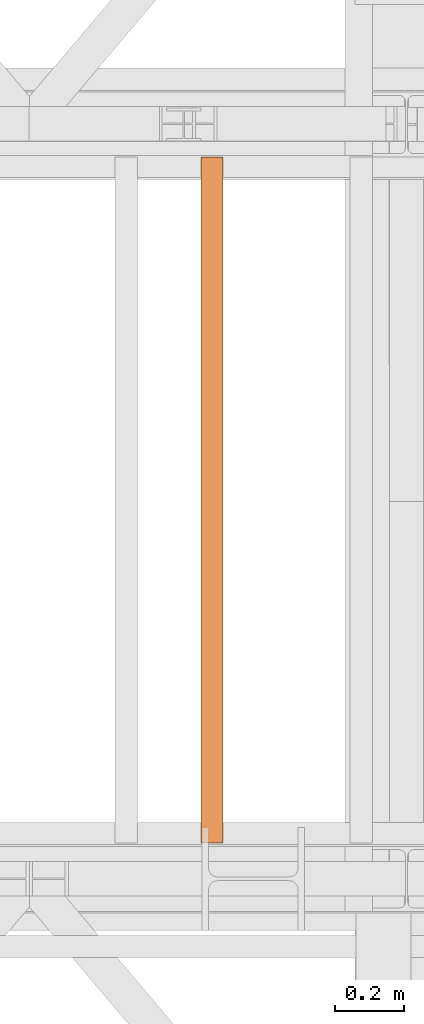
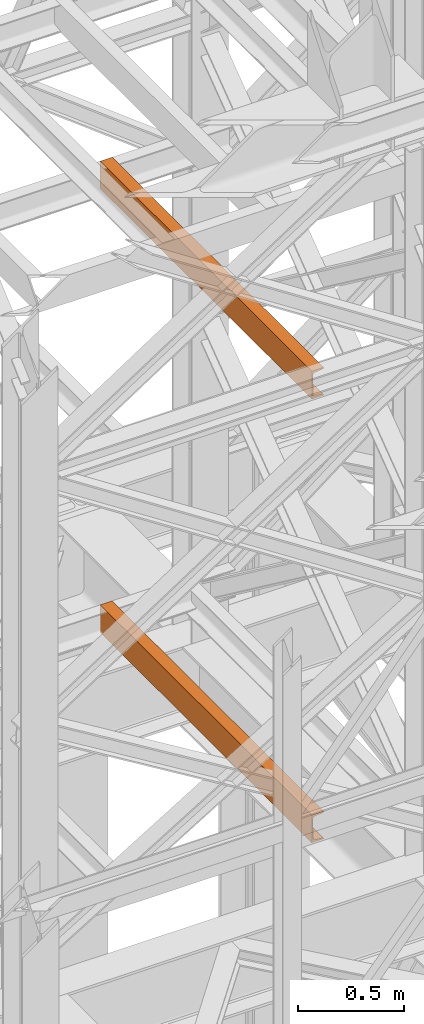
# One storey, part 161 of 208: 2 proxies.
"""IFC2X3 building model written with IfcOpenShell, lengths in millimetres."""

from ifc_helpers import new_model, entity, si_unit, converted_unit, frame, origin, origin_with_axes, place, context, subcontext, project, spatial, faceted_brep, element, save


model = new_model("IFC2X3")

# Units and contexts
model_context = context("Model", 3, precision=1e-05, world=origin())
plan_context = context("Plan", 3, precision=1e-05, world=origin())
body_context = subcontext(model_context, "Body", "Model", "MODEL_VIEW")
ifc_project = project(units=[si_unit("LENGTHUNIT", "METRE", prefix="MILLI"), converted_unit("PLANEANGLEUNIT", "DEGREE", entity("IfcPlaneAngleMeasure", 0.0174532925199433), si_unit("PLANEANGLEUNIT", "RADIAN"), dimensions=[0, 0, 0, 0, 0, 0, 0]), si_unit("AREAUNIT", "SQUARE_METRE"), si_unit("VOLUMEUNIT", "CUBIC_METRE")], contexts=[model_context, plan_context])

# Building, storey
building_placement = place(None, origin())
building = spatial("IfcBuilding", under=ifc_project, at=building_placement, CompositionType="COMPLEX")
storey_placement = place(building_placement, origin_with_axes())
storey = spatial("IfcBuildingStorey", under=building, at=storey_placement, Name="Geschoss", CompositionType="ELEMENT")

# Proxies
proxy_1_placement = place(storey_placement, frame((4893.254968528666, -15857.57439359615, 5524.960005364416), z_axis=(0.0, 0.0, 1.0), x_axis=(1.0, 0.0, 0.0)))
element("IfcBuildingElementProxy", 1, at=proxy_1_placement, inside=storey, context=body_context, shape_type="Brep", body=[
    faceted_brep([(0.01000000000203727, 2000.009997019768, 160.0100000000002), (65.01000000000204, 2000.009997019768, 160.0100000000002), (65.00999999999931, 0.01000000000021828, 160.0100000000002), (0.009999999999308784, 0.01000000000021828, 160.0100000000002), (65.01000000000204, 2000.009997019768, 160.0100000000002), (65.01000000000204, 2000.009997019768, 156.8875719297539), (65.00999999999931, 0.01000000000021828, 156.8875719297539), (65.00999999999931, 0.01000000000021828, 160.0100000000002), (65.01000000000204, 2000.009997019768, 156.8875719297539), (64.76726342282927, 2000.009997019768, 155.2717110918293), (64.76726342282655, 0.01000000000021828, 155.2717110918293), (65.00999999999931, 0.01000000000021828, 156.8875719297539), (64.76726342282927, 2000.009997019768, 155.2717110918293), (64.06053228585733, 2000.009997019768, 153.7984655565542), (64.06053228585824, 0.01000000000021828, 153.7984655565542), (64.76726342282655, 0.01000000000021828, 155.2717110918293), (64.06053228585733, 2000.009997019768, 153.7984655565542), (62.95215163847024, 2000.009997019768, 152.5978732961266), (62.95215163846751, 0.01000000000021828, 152.5978732961266), (64.06053228585824, 0.01000000000021828, 153.7984655565542), (62.95215163847024, 2000.009997019768, 152.5978732961266), (61.53995641148504, 2000.009997019768, 151.7759086082897), (61.53995641148231, 0.01000000000021828, 151.7759086082897), (62.95215163846751, 0.01000000000021828, 152.5978732961266), (61.53995641148504, 2000.009997019768, 151.7759086082897), (59.9485987225562, 2000.009997019768, 151.4050878978051), (59.94859872255347, 0.01000000000021828, 151.4050878978051), (61.53995641148231, 0.01000000000021828, 151.7759086082897), (59.9485987225562, 2000.009997019768, 151.4050878978051), (17.1726751660317, 2000.009997019768, 147.9830140132835), (17.17267516602897, 0.01000000000021828, 147.9830140132835), (59.94859872255347, 0.01000000000021828, 151.4050878978051), (17.1726751660317, 2000.009997019768, 147.9830140132835), (14.20840820801095, 2000.009997019768, 147.318026761528), (14.20840820800822, 0.01000000000021828, 147.318026761528), (17.17267516602897, 0.01000000000021828, 147.9830140132835), (14.20840820801095, 2000.009997019768, 147.318026761528), (11.43861959928836, 2000.009997019768, 145.7058782528511), (11.43861959928927, 0.01000000000021828, 145.7058782528511), (14.20840820800822, 0.01000000000021828, 147.318026761528), (11.43861959928836, 2000.009997019768, 145.7058782528511), (9.3226201815487, 2000.009997019768, 143.4138384829421), (9.322620181545972, 0.01000000000021828, 143.4138384829421), (11.43861959928927, 0.01000000000021828, 145.7058782528511), (9.3226201815487, 2000.009997019768, 143.4138384829421), (7.973406192788389, 2000.009997019768, 140.6012788246917), (7.97340619278566, 0.01000000000021828, 140.6012788246917), (9.322620181545972, 0.01000000000021828, 143.4138384829421), (7.973406192788389, 2000.009997019768, 140.6012788246917), (7.510000000002037, 2000.009997019768, 137.5164535886543), (7.509999999999309, 0.01000000000021828, 137.5164535886543), (7.97340619278566, 0.01000000000021828, 140.6012788246917), (7.510000000002037, 2000.009997019768, 137.5164535886543), (7.510000000002037, 2000.009997019768, 22.503546411348), (7.509999999999309, 0.01000000000021828, 22.503546411348), (7.509999999999309, 0.01000000000021828, 137.5164535886543), (7.510000000002037, 2000.009997019768, 22.503546411348), (7.973406192788389, 2000.009997019768, 19.41872117530875), (7.97340619278566, 0.01000000000021828, 19.41872117530875), (7.509999999999309, 0.01000000000021828, 22.503546411348), (7.973406192788389, 2000.009997019768, 19.41872117530875), (9.3226201815487, 2000.009997019768, 16.60616151705835), (9.322620181545972, 0.01000000000021828, 16.60616151705835), (7.97340619278566, 0.01000000000021828, 19.41872117530875), (9.3226201815487, 2000.009997019768, 16.60616151705835), (11.43861959928836, 2000.009997019768, 14.31412174714933), (11.43861959928927, 0.01000000000021828, 14.31412174714933), (9.322620181545972, 0.01000000000021828, 16.60616151705835), (11.43861959928836, 2000.009997019768, 14.31412174714933), (14.13462866898408, 2000.009997019768, 12.74491643400688), (14.13462866898499, 0.01000000000021828, 12.74491643400688), (11.43861959928927, 0.01000000000021828, 14.31412174714933), (14.13462866898408, 2000.009997019768, 12.74491643400688), (17.1726751660317, 2000.009997019768, 12.03698598671872), (17.17267516602897, 0.01000000000021828, 12.03698598671872), (14.13462866898499, 0.01000000000021828, 12.74491643400688), (17.1726751660317, 2000.009997019768, 12.03698598671872), (59.9485987225562, 2000.009997019768, 8.614912102195376), (59.94859872255347, 0.01000000000021828, 8.614912102195376), (17.17267516602897, 0.01000000000021828, 12.03698598671872), (59.9485987225562, 2000.009997019768, 8.614912102195376), (61.53995641148504, 2000.009997019768, 8.244091391710754), (61.53995641148231, 0.01000000000021828, 8.244091391710754), (59.94859872255347, 0.01000000000021828, 8.614912102195376), (61.53995641148504, 2000.009997019768, 8.244091391710754), (62.95215163847024, 2000.009997019768, 7.422126703873801), (62.95215163846751, 0.01000000000021828, 7.422126703873801), (61.53995641148231, 0.01000000000021828, 8.244091391710754), (62.95215163847024, 2000.009997019768, 7.422126703873801), (64.06053228585733, 2000.009997019768, 6.221534443446217), (64.06053228585824, 0.01000000000021828, 6.221534443446217), (62.95215163846751, 0.01000000000021828, 7.422126703873801), (64.06053228585733, 2000.009997019768, 6.221534443446217), (64.76726342282927, 2000.009997019768, 4.748288908172981), (64.76726342282655, 0.01000000000021828, 4.748288908172981), (64.06053228585824, 0.01000000000021828, 6.221534443446217), (64.76726342282927, 2000.009997019768, 4.748288908172981), (65.01000000000204, 2000.009997019768, 0.01000000000021828), (65.00999999999931, 0.01000000000021828, 0.01000000000021828), (64.76726342282655, 0.01000000000021828, 4.748288908172981), (65.01000000000204, 2000.009997019768, 0.01000000000021828), (0.01000000000203727, 2000.009997019768, 0.01000000000021828), (0.009999999999308784, 0.01000000000021828, 0.01000000000021828), (65.00999999999931, 0.01000000000021828, 0.01000000000021828), (0.01000000000203727, 2000.009997019768, 0.01000000000021828), (0.01000000000203727, 2000.009997019768, 160.0100000000002), (0.009999999999308784, 0.01000000000021828, 160.0100000000002), (0.009999999999308784, 0.01000000000021828, 0.01000000000021828), (0.01000000000203727, 2000.009997019768, 160.0100000000002), (0.01000000000203727, 2000.009997019768, 0.01000000000021828), (65.01000000000204, 2000.009997019768, 0.01000000000021828), (64.76726342282927, 2000.009997019768, 4.748288908172981), (64.06053228585733, 2000.009997019768, 6.221534443446217), (62.95215163847024, 2000.009997019768, 7.422126703873801), (61.53995641148504, 2000.009997019768, 8.244091391710754), (59.9485987225562, 2000.009997019768, 8.614912102195376), (17.1726751660317, 2000.009997019768, 12.03698598671872), (14.13462866898408, 2000.009997019768, 12.74491643400688), (11.43861959928836, 2000.009997019768, 14.31412174714933), (9.3226201815487, 2000.009997019768, 16.60616151705835), (7.973406192788389, 2000.009997019768, 19.41872117530875), (7.510000000002037, 2000.009997019768, 22.503546411348), (7.510000000002037, 2000.009997019768, 137.5164535886543), (7.973406192788389, 2000.009997019768, 140.6012788246917), (9.3226201815487, 2000.009997019768, 143.4138384829421), (11.43861959928836, 2000.009997019768, 145.7058782528511), (14.20840820801095, 2000.009997019768, 147.318026761528), (17.1726751660317, 2000.009997019768, 147.9830140132835), (59.9485987225562, 2000.009997019768, 151.4050878978051), (61.53995641148504, 2000.009997019768, 151.7759086082897), (62.95215163847024, 2000.009997019768, 152.5978732961266), (64.06053228585733, 2000.009997019768, 153.7984655565542), (64.76726342282927, 2000.009997019768, 155.2717110918293), (65.01000000000204, 2000.009997019768, 156.8875719297539), (65.01000000000204, 2000.009997019768, 160.0100000000002), (0.009999999999308784, 0.01000000000021828, 160.0100000000002), (65.00999999999931, 0.01000000000021828, 160.0100000000002), (65.00999999999931, 0.01000000000021828, 156.8875719297539), (64.76726342282655, 0.01000000000021828, 155.2717110918293), (64.06053228585824, 0.01000000000021828, 153.7984655565542), (62.95215163846751, 0.01000000000021828, 152.5978732961266), (61.53995641148231, 0.01000000000021828, 151.7759086082897), (59.94859872255347, 0.01000000000021828, 151.4050878978051), (17.17267516602897, 0.01000000000021828, 147.9830140132835), (14.20840820800822, 0.01000000000021828, 147.318026761528), (11.43861959928927, 0.01000000000021828, 145.7058782528511), (9.322620181545972, 0.01000000000021828, 143.4138384829421), (7.97340619278566, 0.01000000000021828, 140.6012788246917), (7.509999999999309, 0.01000000000021828, 137.5164535886543), (7.509999999999309, 0.01000000000021828, 22.503546411348), (7.97340619278566, 0.01000000000021828, 19.41872117530875), (9.322620181545972, 0.01000000000021828, 16.60616151705835), (11.43861959928927, 0.01000000000021828, 14.31412174714933), (14.13462866898499, 0.01000000000021828, 12.74491643400688), (17.17267516602897, 0.01000000000021828, 12.03698598671872), (59.94859872255347, 0.01000000000021828, 8.614912102195376), (61.53995641148231, 0.01000000000021828, 8.244091391710754), (62.95215163846751, 0.01000000000021828, 7.422126703873801), (64.06053228585824, 0.01000000000021828, 6.221534443446217), (64.76726342282655, 0.01000000000021828, 4.748288908172981), (65.00999999999931, 0.01000000000021828, 0.01000000000021828), (0.009999999999308784, 0.01000000000021828, 0.01000000000021828)], [[[0, 1, 2, 3]], [[4, 5, 6, 7]], [[8, 9, 10, 11]], [[12, 13, 14, 15]], [[16, 17, 18, 19]], [[20, 21, 22, 23]], [[24, 25, 26, 27]], [[28, 29, 30, 31]], [[32, 33, 34, 35]], [[36, 37, 38, 39]], [[40, 41, 42, 43]], [[44, 45, 46, 47]], [[48, 49, 50, 51]], [[52, 53, 54, 55]], [[56, 57, 58, 59]], [[60, 61, 62, 63]], [[64, 65, 66, 67]], [[68, 69, 70, 71]], [[72, 73, 74, 75]], [[76, 77, 78, 79]], [[80, 81, 82, 83]], [[84, 85, 86, 87]], [[88, 89, 90, 91]], [[92, 93, 94, 95]], [[96, 97, 98, 99]], [[100, 101, 102, 103]], [[104, 105, 106, 107]], [[108, 109, 110, 111, 112, 113, 114, 115, 116, 117, 118, 119, 120, 121, 122, 123, 124, 125, 126, 127, 128, 129, 130, 131, 132, 133, 134]], [[135, 136, 137, 138, 139, 140, 141, 142, 143, 144, 145, 146, 147, 148, 149, 150, 151, 152, 153, 154, 155, 156, 157, 158, 159, 160, 161]]], orient=[[False], [False], [False], [False], [False], [False], [False], [False], [False], [False], [False], [False], [False], [False], [False], [False], [False], [False], [False], [False], [False], [False], [False], [False], [False], [False], [False], [False], [False]]),
])
proxy_2_placement = place(storey_placement, frame((4893.254968528666, -15857.57439359615, 8084.960005364416), z_axis=(0.0, 0.0, 1.0), x_axis=(1.0, 0.0, 0.0)))
element("IfcBuildingElementProxy", 2, at=proxy_2_placement, inside=storey, context=body_context, shape_type="Brep", body=[
    faceted_brep([(0.01000000000203727, 2000.009997019768, 160.0099999999993), (65.01000000000204, 2000.009997019768, 160.0099999999993), (65.00999999999931, 0.01000000000021828, 160.0099999999993), (0.009999999999308784, 0.01000000000021828, 160.0099999999993), (65.01000000000204, 2000.009997019768, 160.0099999999993), (65.01000000000204, 2000.009997019768, 156.8875719297548), (65.00999999999931, 0.01000000000021828, 156.8875719297548), (65.00999999999931, 0.01000000000021828, 160.0099999999993), (65.01000000000204, 2000.009997019768, 156.8875719297548), (64.76726342282927, 2000.009997019768, 155.2717110918284), (64.76726342282655, 0.01000000000021828, 155.2717110918284), (65.00999999999931, 0.01000000000021828, 156.8875719297548), (64.76726342282927, 2000.009997019768, 155.2717110918284), (64.06053228585733, 2000.009997019768, 153.7984655565533), (64.06053228585824, 0.01000000000021828, 153.7984655565533), (64.76726342282655, 0.01000000000021828, 155.2717110918284), (64.06053228585733, 2000.009997019768, 153.7984655565533), (62.95215163847024, 2000.009997019768, 152.5978732961276), (62.95215163846751, 0.01000000000021828, 152.5978732961276), (64.06053228585824, 0.01000000000021828, 153.7984655565533), (62.95215163847024, 2000.009997019768, 152.5978732961276), (61.53995641148504, 2000.009997019768, 151.7759086082888), (61.53995641148231, 0.01000000000021828, 151.7759086082888), (62.95215163846751, 0.01000000000021828, 152.5978732961276), (61.53995641148504, 2000.009997019768, 151.7759086082888), (59.9485987225562, 2000.009997019768, 151.405087897806), (59.94859872255347, 0.01000000000021828, 151.405087897806), (61.53995641148231, 0.01000000000021828, 151.7759086082888), (59.9485987225562, 2000.009997019768, 151.405087897806), (17.1726751660317, 2000.009997019768, 147.9830140132845), (17.17267516602897, 0.01000000000021828, 147.9830140132845), (59.94859872255347, 0.01000000000021828, 151.405087897806), (17.1726751660317, 2000.009997019768, 147.9830140132845), (14.20840820801095, 2000.009997019768, 147.3180267615289), (14.20840820800822, 0.01000000000021828, 147.3180267615289), (17.17267516602897, 0.01000000000021828, 147.9830140132845), (14.20840820801095, 2000.009997019768, 147.3180267615289), (11.43861959928836, 2000.009997019768, 145.705878252852), (11.43861959928927, 0.01000000000021828, 145.705878252852), (14.20840820800822, 0.01000000000021828, 147.3180267615289), (11.43861959928836, 2000.009997019768, 145.705878252852), (9.3226201815487, 2000.009997019768, 143.413838482943), (9.322620181545972, 0.01000000000021828, 143.413838482943), (11.43861959928927, 0.01000000000021828, 145.705878252852), (9.3226201815487, 2000.009997019768, 143.413838482943), (7.973406192788389, 2000.009997019768, 140.6012788246926), (7.97340619278566, 0.01000000000021828, 140.6012788246926), (9.322620181545972, 0.01000000000021828, 143.413838482943), (7.973406192788389, 2000.009997019768, 140.6012788246926), (7.510000000002037, 2000.009997019768, 137.5164535886552), (7.509999999999309, 0.01000000000021828, 137.5164535886552), (7.97340619278566, 0.01000000000021828, 140.6012788246926), (7.510000000002037, 2000.009997019768, 137.5164535886552), (7.510000000002037, 2000.009997019768, 22.503546411348), (7.509999999999309, 0.01000000000021828, 22.503546411348), (7.509999999999309, 0.01000000000021828, 137.5164535886552), (7.510000000002037, 2000.009997019768, 22.503546411348), (7.973406192788389, 2000.009997019768, 19.41872117530875), (7.97340619278566, 0.01000000000021828, 19.41872117530875), (7.509999999999309, 0.01000000000021828, 22.503546411348), (7.973406192788389, 2000.009997019768, 19.41872117530875), (9.3226201815487, 2000.009997019768, 16.60616151705835), (9.322620181545972, 0.01000000000021828, 16.60616151705835), (7.97340619278566, 0.01000000000021828, 19.41872117530875), (9.3226201815487, 2000.009997019768, 16.60616151705835), (11.43861959928836, 2000.009997019768, 14.31412174714933), (11.43861959928927, 0.01000000000021828, 14.31412174714933), (9.322620181545972, 0.01000000000021828, 16.60616151705835), (11.43861959928836, 2000.009997019768, 14.31412174714933), (14.13462866898408, 2000.009997019768, 12.74491643400688), (14.13462866898499, 0.01000000000021828, 12.74491643400688), (11.43861959928927, 0.01000000000021828, 14.31412174714933), (14.13462866898408, 2000.009997019768, 12.74491643400688), (17.1726751660317, 2000.009997019768, 12.03698598671872), (17.17267516602897, 0.01000000000021828, 12.03698598671872), (14.13462866898499, 0.01000000000021828, 12.74491643400688), (17.1726751660317, 2000.009997019768, 12.03698598671872), (59.9485987225562, 2000.009997019768, 8.614912102195376), (59.94859872255347, 0.01000000000021828, 8.614912102195376), (17.17267516602897, 0.01000000000021828, 12.03698598671872), (59.9485987225562, 2000.009997019768, 8.614912102195376), (61.53995641148504, 2000.009997019768, 8.244091391710754), (61.53995641148231, 0.01000000000021828, 8.244091391710754), (59.94859872255347, 0.01000000000021828, 8.614912102195376), (61.53995641148504, 2000.009997019768, 8.244091391710754), (62.95215163847024, 2000.009997019768, 7.422126703873801), (62.95215163846751, 0.01000000000021828, 7.422126703873801), (61.53995641148231, 0.01000000000021828, 8.244091391710754), (62.95215163847024, 2000.009997019768, 7.422126703873801), (64.06053228585733, 2000.009997019768, 6.221534443446217), (64.06053228585824, 0.01000000000021828, 6.221534443446217), (62.95215163846751, 0.01000000000021828, 7.422126703873801), (64.06053228585733, 2000.009997019768, 6.221534443446217), (64.76726342282927, 2000.009997019768, 4.748288908172981), (64.76726342282655, 0.01000000000021828, 4.748288908172981), (64.06053228585824, 0.01000000000021828, 6.221534443446217), (64.76726342282927, 2000.009997019768, 4.748288908172981), (65.01000000000204, 2000.009997019768, 0.01000000000021828), (65.00999999999931, 0.01000000000021828, 0.01000000000021828), (64.76726342282655, 0.01000000000021828, 4.748288908172981), (65.01000000000204, 2000.009997019768, 0.01000000000021828), (0.01000000000203727, 2000.009997019768, 0.01000000000021828), (0.009999999999308784, 0.01000000000021828, 0.01000000000021828), (65.00999999999931, 0.01000000000021828, 0.01000000000021828), (0.01000000000203727, 2000.009997019768, 0.01000000000021828), (0.01000000000203727, 2000.009997019768, 160.0099999999993), (0.009999999999308784, 0.01000000000021828, 160.0099999999993), (0.009999999999308784, 0.01000000000021828, 0.01000000000021828), (0.01000000000203727, 2000.009997019768, 160.0099999999993), (0.01000000000203727, 2000.009997019768, 0.01000000000021828), (65.01000000000204, 2000.009997019768, 0.01000000000021828), (64.76726342282927, 2000.009997019768, 4.748288908172981), (64.06053228585733, 2000.009997019768, 6.221534443446217), (62.95215163847024, 2000.009997019768, 7.422126703873801), (61.53995641148504, 2000.009997019768, 8.244091391710754), (59.9485987225562, 2000.009997019768, 8.614912102195376), (17.1726751660317, 2000.009997019768, 12.03698598671872), (14.13462866898408, 2000.009997019768, 12.74491643400688), (11.43861959928836, 2000.009997019768, 14.31412174714933), (9.3226201815487, 2000.009997019768, 16.60616151705835), (7.973406192788389, 2000.009997019768, 19.41872117530875), (7.510000000002037, 2000.009997019768, 22.503546411348), (7.510000000002037, 2000.009997019768, 137.5164535886552), (7.973406192788389, 2000.009997019768, 140.6012788246926), (9.3226201815487, 2000.009997019768, 143.413838482943), (11.43861959928836, 2000.009997019768, 145.705878252852), (14.20840820801095, 2000.009997019768, 147.3180267615289), (17.1726751660317, 2000.009997019768, 147.9830140132845), (59.9485987225562, 2000.009997019768, 151.405087897806), (61.53995641148504, 2000.009997019768, 151.7759086082888), (62.95215163847024, 2000.009997019768, 152.5978732961276), (64.06053228585733, 2000.009997019768, 153.7984655565533), (64.76726342282927, 2000.009997019768, 155.2717110918284), (65.01000000000204, 2000.009997019768, 156.8875719297548), (65.01000000000204, 2000.009997019768, 160.0099999999993), (0.009999999999308784, 0.01000000000021828, 160.0099999999993), (65.00999999999931, 0.01000000000021828, 160.0099999999993), (65.00999999999931, 0.01000000000021828, 156.8875719297548), (64.76726342282655, 0.01000000000021828, 155.2717110918284), (64.06053228585824, 0.01000000000021828, 153.7984655565533), (62.95215163846751, 0.01000000000021828, 152.5978732961276), (61.53995641148231, 0.01000000000021828, 151.7759086082888), (59.94859872255347, 0.01000000000021828, 151.405087897806), (17.17267516602897, 0.01000000000021828, 147.9830140132845), (14.20840820800822, 0.01000000000021828, 147.3180267615289), (11.43861959928927, 0.01000000000021828, 145.705878252852), (9.322620181545972, 0.01000000000021828, 143.413838482943), (7.97340619278566, 0.01000000000021828, 140.6012788246926), (7.509999999999309, 0.01000000000021828, 137.5164535886552), (7.509999999999309, 0.01000000000021828, 22.503546411348), (7.97340619278566, 0.01000000000021828, 19.41872117530875), (9.322620181545972, 0.01000000000021828, 16.60616151705835), (11.43861959928927, 0.01000000000021828, 14.31412174714933), (14.13462866898499, 0.01000000000021828, 12.74491643400688), (17.17267516602897, 0.01000000000021828, 12.03698598671872), (59.94859872255347, 0.01000000000021828, 8.614912102195376), (61.53995641148231, 0.01000000000021828, 8.244091391710754), (62.95215163846751, 0.01000000000021828, 7.422126703873801), (64.06053228585824, 0.01000000000021828, 6.221534443446217), (64.76726342282655, 0.01000000000021828, 4.748288908172981), (65.00999999999931, 0.01000000000021828, 0.01000000000021828), (0.009999999999308784, 0.01000000000021828, 0.01000000000021828)], [[[0, 1, 2, 3]], [[4, 5, 6, 7]], [[8, 9, 10, 11]], [[12, 13, 14, 15]], [[16, 17, 18, 19]], [[20, 21, 22, 23]], [[24, 25, 26, 27]], [[28, 29, 30, 31]], [[32, 33, 34, 35]], [[36, 37, 38, 39]], [[40, 41, 42, 43]], [[44, 45, 46, 47]], [[48, 49, 50, 51]], [[52, 53, 54, 55]], [[56, 57, 58, 59]], [[60, 61, 62, 63]], [[64, 65, 66, 67]], [[68, 69, 70, 71]], [[72, 73, 74, 75]], [[76, 77, 78, 79]], [[80, 81, 82, 83]], [[84, 85, 86, 87]], [[88, 89, 90, 91]], [[92, 93, 94, 95]], [[96, 97, 98, 99]], [[100, 101, 102, 103]], [[104, 105, 106, 107]], [[108, 109, 110, 111, 112, 113, 114, 115, 116, 117, 118, 119, 120, 121, 122, 123, 124, 125, 126, 127, 128, 129, 130, 131, 132, 133, 134]], [[135, 136, 137, 138, 139, 140, 141, 142, 143, 144, 145, 146, 147, 148, 149, 150, 151, 152, 153, 154, 155, 156, 157, 158, 159, 160, 161]]], orient=[[False], [False], [False], [False], [False], [False], [False], [False], [False], [False], [False], [False], [False], [False], [False], [False], [False], [False], [False], [False], [False], [False], [False], [False], [False], [False], [False], [False], [False]]),
])

save(model, "model.ifc")
